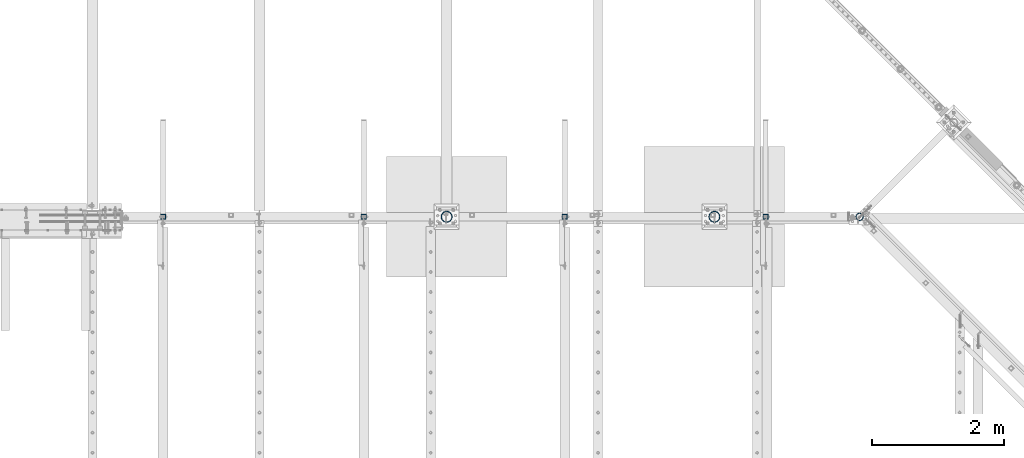
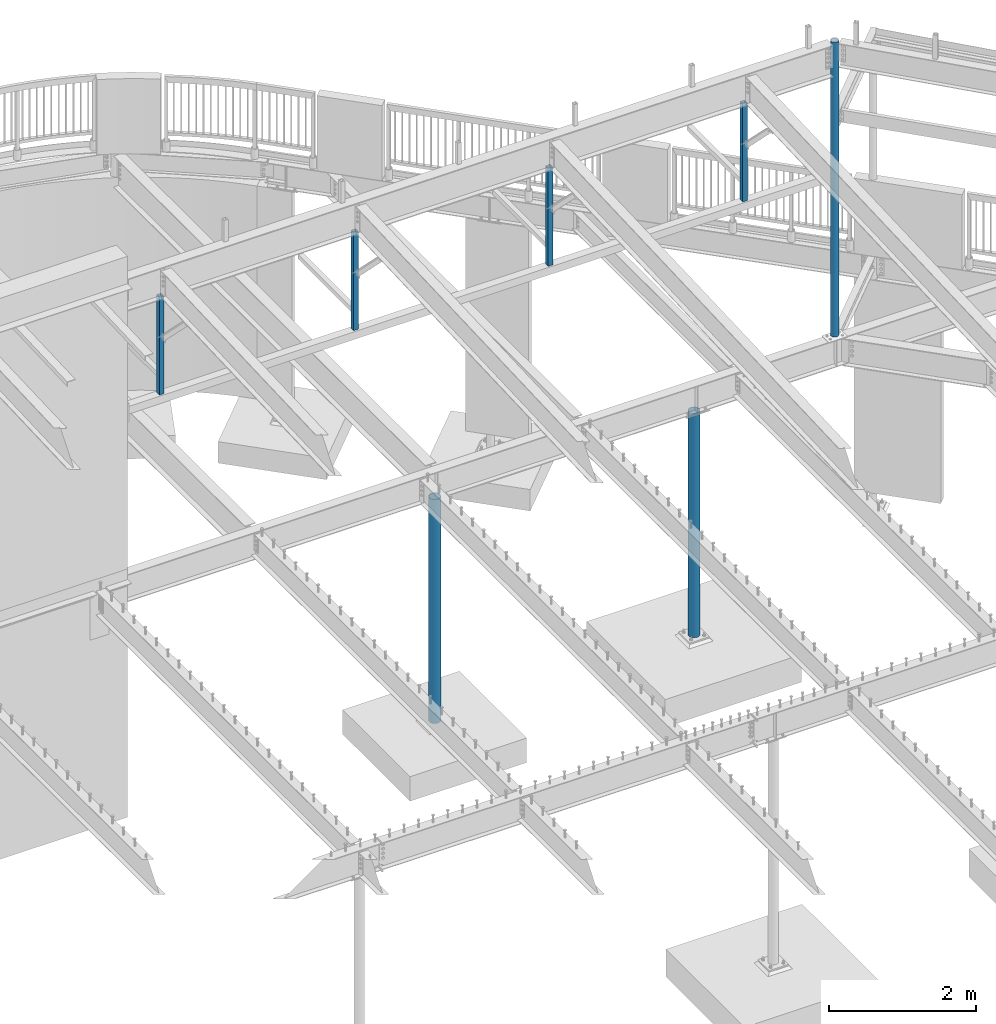
# One storey, part 128 of 975: 7 columns.
"""IFC2X3 building model written with IfcOpenShell, lengths in millimetres."""

from ifc_helpers import new_model, si_unit, frame, origin_with_axes, place, context, subcontext, project, spatial, faceted_brep, material, type_object, element, save


model = new_model("IFC2X3")

# Units and contexts
model_context = context("Model", 3, precision=1e-05, world=origin_with_axes())
body_context = subcontext(model_context, "Body", "Model", "MODEL_VIEW")
ifc_project = project(units=[si_unit("LENGTHUNIT", "METRE", prefix="MILLI"), si_unit("AREAUNIT", "SQUARE_METRE"), si_unit("VOLUMEUNIT", "CUBIC_METRE"), si_unit("MASSUNIT", "GRAM", prefix="KILO"), si_unit("TIMEUNIT", "SECOND"), si_unit("PLANEANGLEUNIT", "RADIAN"), si_unit("SOLIDANGLEUNIT", "STERADIAN"), si_unit("THERMODYNAMICTEMPERATUREUNIT", "DEGREE_CELSIUS"), si_unit("LUMINOUSINTENSITYUNIT", "LUMEN")], contexts=[model_context])

# Site, building, storey
site_placement = place(None, origin_with_axes())
site = spatial("IfcSite", under=ifc_project, at=site_placement, CompositionType="ELEMENT")
building_placement = place(site_placement, origin_with_axes())
building = spatial("IfcBuilding", under=site, at=building_placement, Name="Undefined", CompositionType="ELEMENT")
storey_placement = place(building_placement, origin_with_axes())
storey = spatial("IfcBuildingStorey", under=building, at=storey_placement, Name="Undefined", CompositionType="ELEMENT", Elevation=0.0)

# Columns
ifc_material_1 = material()
column_type_1 = type_object("IfcColumnType", Name="HSS3X3X1/4", PredefinedType="NOTDEFINED")
for number, where, z_axis, x_axis in (
    (1, (23701.375, 20647.025, 6686.55), (1.0, 0.0, 0.0), (0.0, 0.0, 1.0)),
    (2, (20653.375, 20647.025, 6686.55), (1.0, 0.0, 0.0), (0.0, 0.0, 1.0)),
    (3, (17605.375, 20647.025, 6686.55), (1.0, 0.0, 0.0), (0.0, 0.0, 1.0)),
    (4, (14557.375, 20646.9149014879, 6686.55), (1.0, 0.0, 0.0), (0.0, 0.0, 1.0)),
):
    element("IfcColumn", number, at=place(storey_placement, frame(where, z_axis=z_axis, x_axis=x_axis)), inside=storey, type_object=column_type_1, material=ifc_material_1, ObjectType="HSS3X3X1/4", context=body_context, shape_type="Brep", body=[
        faceted_brep([(-5.45696821063757e-11, 31.7499999999909, -31.75000000002), (0.0, -31.7500000000146, -31.7500000000582), (1622.42500000001, -31.7499999992797, -31.75), (1622.42499999999, 31.7500000007203, -31.75), (0.0, -31.7500000000564, 31.7500000000073), (1622.42500000001, -31.7499999992797, 31.75), (0.0, 31.7500000000127, 31.7500000000582), (1622.42499999999, 31.7500000007203, 31.75), (-6.18456397205591e-11, 38.0999999999876, -38.1000000000258), (1.45519152283669e-10, 38.1000000000295, 38.1000000000386), (1622.42499999998, 38.1000000007189, 38.0999999999985), (1622.42499999998, 38.1000000007189, -38.0999999999985), (1.72803993336856e-11, -38.0999999999985, 38.0999999999985), (1622.42500000002, -38.0999999992819, 38.0999999999985), (-1.41881173476577e-10, -38.1000000000258, -38.1000000000386), (1622.42500000002, -38.0999999992819, -38.0999999999985)], [[[0, 1, 2, 3]], [[1, 4, 5, 2]], [[4, 6, 7, 5]], [[6, 0, 3, 7]], [[8, 9, 10, 11]], [[9, 12, 13, 10]], [[12, 14, 15, 13]], [[14, 8, 11, 15]], [[13, 15, 11, 10], [5, 7, 3, 2]], [[14, 12, 9, 8], [6, 4, 1, 0]]]),
    ])
ifc_material_2 = material(Name="STEEL/A53")
column_type_2 = type_object("IfcColumnType", Name="PIPE4STD", PredefinedType="NOTDEFINED")
column_1_placement = place(storey_placement, frame((25126.9920609686, 20647.025, 3937.0), z_axis=(0.0, 1.0, 0.0), x_axis=(0.0, 0.0, 1.0)))
element("IfcColumn", 5, at=column_1_placement, inside=storey, type_object=column_type_2, material=ifc_material_2, Name="COLUMN", ObjectType="PIPE4STD", context=body_context, shape_type="Brep", body=[
    faceted_brep([(12.7000000000007, -51.1301999999359, 6.54836185276508e-11), (12.7000000000007, -48.6277098894352, 15.8001007258354), (4892.675, -48.6277098894752, 15.8001007257917), (4892.675, -51.1301999999996, 0.0), (12.7000000000007, -41.3652007257788, 30.0535775067838), (4892.675, -41.3652007257915, 30.0535775067656), (12.7000000000007, -30.0535775067819, 41.3652007257842), (4892.675, -30.0535775067656, 41.3652007257915), (12.7000000000007, -15.8001007258317, 48.6277098894388), (4892.675, -15.8001007257917, 48.6277098894752), (12.7000000000007, -6.00266503170133e-11, 51.1301999999414), (4892.675, 0.0, 51.1301999999996), (12.7000000000007, 15.8001007257153, 48.6277098894025), (4892.675, 15.8001007257917, 48.6277098894752), (12.7000000000007, 30.0535775066819, 41.3652007257042), (4892.675, 30.0535775067656, 41.3652007257915), (12.7000000000007, 41.3652007257078, 30.0535775066783), (4892.675, 41.3652007257915, 30.0535775067656), (12.7000000000007, 48.6277098894061, 15.8001007257117), (4892.675, 48.6277098894752, 15.8001007257917), (12.7000000000007, 51.1301999999469, -6.54836185276508e-11), (4892.675, 51.1301999999996, 0.0), (12.7000000000007, 48.6277098894425, -15.8001007258354), (4892.675, 48.6277098894752, -15.8001007257917), (12.7000000000007, 41.3652007257861, -30.0535775067838), (4892.675, 41.3652007257915, -30.0535775067656), (12.7000000000007, 30.0535775067892, -41.3652007257842), (4892.675, 30.0535775067656, -41.3652007257915), (12.7000000000007, 15.800100725839, -48.6277098894388), (4892.675, 15.8001007257917, -48.6277098894752), (12.7000000000007, 7.09405867382884e-11, -51.1301999999414), (4892.675, 0.0, -51.1301999999996), (12.7000000000007, -15.8001007257044, -48.6277098893988), (4892.675, -15.8001007257917, -48.6277098894752), (12.7000000000007, -30.0535775066746, -41.3652007257042), (4892.675, -30.0535775067656, -41.3652007257915), (12.7000000000007, -41.3652007257006, -30.0535775066746), (4892.675, -41.3652007257915, -30.0535775067656), (12.7000000000007, -48.6277098893952, -15.800100725708), (4892.675, -48.6277098894752, -15.8001007257917), (12.7000000000007, -57.149999999936, 7.27595761418343e-11), (12.7000000000007, -54.3528799061787, -17.6603212284354), (4892.675, -54.3528799062697, -17.6603212285299), (4892.675, -57.1500000000015, 0.0), (12.7000000000007, -46.2353212284306, -33.5919271684179), (4892.675, -46.235321228527, -33.5919271685161), (12.7000000000007, -33.5919271684143, -46.2353212284324), (4892.675, -33.5919271685161, -46.235321228527), (12.7000000000007, -17.6603212284317, -54.3528799061824), (4892.675, -17.6603212285299, -54.3528799062697), (12.7000000000007, 7.45785655453801e-11, -57.149999999936), (4892.675, 0.0, -57.1500000000015), (12.7000000000007, 17.6603212285845, -54.3528799062296), (4892.675, 17.6603212285299, -54.3528799062697), (12.7000000000007, 33.5919271685379, -46.2353212285198), (4892.675, 33.5919271685161, -46.235321228527), (12.7000000000007, 46.2353212285234, -33.5919271685343), (4892.675, 46.235321228527, -33.5919271685161), (12.7000000000007, 54.3528799062333, -17.6603212285772), (4892.675, 54.3528799062697, -17.6603212285299), (12.7000000000007, 57.1499999999414, -7.27595761418343e-11), (4892.675, 57.1500000000015, 0.0), (12.7000000000007, 54.3528799061896, 17.6603212284354), (4892.675, 54.3528799062697, 17.6603212285299), (12.7000000000007, 46.2353212284361, 33.5919271684179), (4892.675, 46.235321228527, 33.5919271685161), (12.7000000000007, 33.5919271684197, 46.2353212284361), (4892.675, 33.5919271685161, 46.235321228527), (12.7000000000007, 17.6603212284426, 54.3528799061824), (4892.675, 17.6603212285299, 54.3528799062697), (12.7000000000007, -6.91215973347425e-11, 57.1499999999396), (4892.675, 0.0, 57.1500000000015), (12.7000000000007, -17.6603212285736, 54.3528799062333), (4892.675, -17.6603212285299, 54.3528799062697), (12.7000000000007, -33.5919271685307, 46.2353212285234), (4892.675, -33.5919271685161, 46.235321228527), (12.7000000000007, -46.2353212285161, 33.5919271685343), (4892.675, -46.235321228527, 33.5919271685161), (12.7000000000007, -54.3528799062224, 17.6603212285772), (4892.675, -54.3528799062697, 17.6603212285299)], [[[0, 1, 2, 3]], [[1, 4, 5, 2]], [[4, 6, 7, 5]], [[6, 8, 9, 7]], [[8, 10, 11, 9]], [[10, 12, 13, 11]], [[12, 14, 15, 13]], [[14, 16, 17, 15]], [[16, 18, 19, 17]], [[18, 20, 21, 19]], [[20, 22, 23, 21]], [[22, 24, 25, 23]], [[24, 26, 27, 25]], [[26, 28, 29, 27]], [[28, 30, 31, 29]], [[30, 32, 33, 31]], [[32, 34, 35, 33]], [[34, 36, 37, 35]], [[36, 38, 39, 37]], [[38, 0, 3, 39]], [[40, 41, 42, 43]], [[41, 44, 45, 42]], [[44, 46, 47, 45]], [[46, 48, 49, 47]], [[48, 50, 51, 49]], [[50, 52, 53, 51]], [[52, 54, 55, 53]], [[54, 56, 57, 55]], [[56, 58, 59, 57]], [[58, 60, 61, 59]], [[60, 62, 63, 61]], [[62, 64, 65, 63]], [[64, 66, 67, 65]], [[66, 68, 69, 67]], [[68, 70, 71, 69]], [[70, 72, 73, 71]], [[72, 74, 75, 73]], [[74, 76, 77, 75]], [[76, 78, 79, 77]], [[78, 40, 43, 79]], [[45, 47, 49, 51, 53, 55, 57, 59, 61, 63, 65, 67, 69, 71, 73, 75, 77, 79, 43, 42], [5, 7, 9, 11, 13, 15, 17, 19, 21, 23, 25, 27, 29, 31, 33, 35, 37, 39, 3, 2]], [[78, 76, 74, 72, 70, 68, 66, 64, 62, 60, 58, 56, 54, 52, 50, 48, 46, 44, 41, 40], [38, 36, 34, 32, 30, 28, 26, 24, 22, 20, 18, 16, 14, 12, 10, 8, 6, 4, 1, 0]]]),
])
column_type_3 = type_object("IfcColumnType", Name="PIPE6STD", PredefinedType="NOTDEFINED")
column_2_placement = place(storey_placement, frame((22923.5, 20647.025, -266.7), z_axis=(0.0, 1.0, 0.0), x_axis=(0.0, 0.0, 1.0)))
element("IfcColumn", 6, at=column_2_placement, inside=storey, type_object=column_type_3, material=ifc_material_2, Name="COLUMN", ObjectType="PIPE6STD", context=body_context, shape_type="Brep", body=[
    faceted_brep([(25.3999999999999, -77.0889999999999, 0.0), (25.3999999999999, -74.4622560227981, 19.9521013679077), (3736.975, -74.4622560227981, 19.9521013679077), (3736.975, -77.0889999999999, 0.0), (25.3999999999999, -66.7610323523368, 38.5445), (3736.975, -66.7610323523368, 38.5445), (25.3999999999999, -54.5101546548904, 54.5101546548904), (3736.975, -54.5101546548904, 54.5101546548904), (25.3999999999999, -38.5445, 66.7610323523404), (3736.975, -38.5445, 66.7610323523404), (25.3999999999999, -19.9521013679077, 74.4622560227981), (3736.975, -19.9521013679077, 74.4622560227981), (25.3999999999999, 0.0, 77.0889999999999), (3736.975, 0.0, 77.0889999999999), (25.3999999999999, 19.9521013679077, 74.4622560227981), (3736.975, 19.9521013679077, 74.4622560227981), (25.3999999999999, 38.5445, 66.7610323523368), (3736.975, 38.5445, 66.7610323523368), (25.3999999999999, 54.5101546548904, 54.5101546548904), (3736.975, 54.5101546548904, 54.5101546548904), (25.3999999999999, 66.7610323523404, 38.5445), (3736.975, 66.7610323523404, 38.5445), (25.3999999999999, 74.4622560227981, 19.9521013679077), (3736.975, 74.4622560227981, 19.9521013679077), (25.3999999999999, 77.0889999999999, 0.0), (3736.975, 77.0889999999999, 0.0), (25.3999999999999, 74.4622560227981, -19.9521013679077), (3736.975, 74.4622560227981, -19.9521013679077), (25.3999999999999, 66.7610323523368, -38.5445), (3736.975, 66.7610323523368, -38.5445), (25.3999999999999, 54.5101546548904, -54.5101546548904), (3736.975, 54.5101546548904, -54.5101546548904), (25.3999999999999, 38.5445, -66.7610323523404), (3736.975, 38.5445, -66.7610323523404), (25.3999999999999, 19.9521013679077, -74.4622560227981), (3736.975, 19.9521013679077, -74.4622560227981), (25.3999999999999, 0.0, -77.0889999999999), (3736.975, 0.0, -77.0889999999999), (25.3999999999999, -19.9521013679077, -74.4622560227981), (3736.975, -19.9521013679077, -74.4622560227981), (25.3999999999999, -38.5445, -66.7610323523404), (3736.975, -38.5445, -66.7610323523404), (25.3999999999999, -54.5101546548904, -54.5101546548904), (3736.975, -54.5101546548904, -54.5101546548904), (25.3999999999999, -66.7610323523404, -38.5445), (3736.975, -66.7610323523404, -38.5445), (25.3999999999999, -74.4622560227981, -19.9521013679077), (3736.975, -74.4622560227981, -19.9521013679077), (25.3999999999999, -84.2010000000009, 0.0), (25.3999999999999, -81.3319204993641, -21.792822416679), (3736.975, -81.3319204993641, -21.792822416679), (3736.975, -84.2010000000009, 0.0), (25.3999999999999, -72.9202050240528, -42.1005000000005), (3736.975, -72.9202050240528, -42.1005000000005), (25.3999999999999, -59.5390980826887, -59.5390980826887), (3736.975, -59.5390980826887, -59.5390980826887), (25.3999999999999, -42.1005000000005, -72.9202050240528), (3736.975, -42.1005000000005, -72.9202050240528), (25.3999999999999, -21.792822416679, -81.3319204993641), (3736.975, -21.792822416679, -81.3319204993641), (25.3999999999999, 0.0, -84.2010000000009), (3736.975, 0.0, -84.2010000000009), (25.3999999999999, 21.792822416679, -81.3319204993641), (3736.975, 21.792822416679, -81.3319204993641), (25.3999999999999, 42.1005000000005, -72.9202050240528), (3736.975, 42.1005000000005, -72.9202050240528), (25.3999999999999, 59.5390980826887, -59.5390980826887), (3736.975, 59.5390980826887, -59.5390980826887), (25.3999999999999, 72.9202050240528, -42.1005000000005), (3736.975, 72.9202050240528, -42.1005000000005), (25.3999999999999, 81.3319204993641, -21.792822416679), (3736.975, 81.3319204993641, -21.792822416679), (25.3999999999999, 84.2010000000009, 0.0), (3736.975, 84.2010000000009, 0.0), (25.3999999999999, 81.3319204993641, 21.792822416679), (3736.975, 81.3319204993641, 21.792822416679), (25.3999999999999, 72.9202050240528, 42.1005000000005), (3736.975, 72.9202050240528, 42.1005000000005), (25.3999999999999, 59.5390980826887, 59.5390980826887), (3736.975, 59.5390980826887, 59.5390980826887), (25.3999999999999, 42.1005000000005, 72.9202050240528), (3736.975, 42.1005000000005, 72.9202050240528), (25.3999999999999, 21.792822416679, 81.3319204993641), (3736.975, 21.792822416679, 81.3319204993641), (25.3999999999999, 0.0, 84.2010000000009), (3736.975, 0.0, 84.2010000000009), (25.3999999999999, -21.792822416679, 81.3319204993641), (3736.975, -21.792822416679, 81.3319204993641), (25.3999999999999, -42.1005000000005, 72.9202050240528), (3736.975, -42.1005000000005, 72.9202050240528), (25.3999999999999, -59.5390980826887, 59.5390980826887), (3736.975, -59.5390980826887, 59.5390980826887), (25.3999999999999, -72.9202050240528, 42.1005000000005), (3736.975, -72.9202050240528, 42.1005000000005), (25.3999999999999, -81.3319204993641, 21.792822416679), (3736.975, -81.3319204993641, 21.792822416679)], [[[0, 1, 2, 3]], [[1, 4, 5, 2]], [[4, 6, 7, 5]], [[6, 8, 9, 7]], [[8, 10, 11, 9]], [[10, 12, 13, 11]], [[12, 14, 15, 13]], [[14, 16, 17, 15]], [[16, 18, 19, 17]], [[18, 20, 21, 19]], [[20, 22, 23, 21]], [[22, 24, 25, 23]], [[24, 26, 27, 25]], [[26, 28, 29, 27]], [[28, 30, 31, 29]], [[30, 32, 33, 31]], [[32, 34, 35, 33]], [[34, 36, 37, 35]], [[36, 38, 39, 37]], [[38, 40, 41, 39]], [[40, 42, 43, 41]], [[42, 44, 45, 43]], [[44, 46, 47, 45]], [[46, 0, 3, 47]], [[48, 49, 50, 51]], [[49, 52, 53, 50]], [[52, 54, 55, 53]], [[54, 56, 57, 55]], [[56, 58, 59, 57]], [[58, 60, 61, 59]], [[60, 62, 63, 61]], [[62, 64, 65, 63]], [[64, 66, 67, 65]], [[66, 68, 69, 67]], [[68, 70, 71, 69]], [[70, 72, 73, 71]], [[72, 74, 75, 73]], [[74, 76, 77, 75]], [[76, 78, 79, 77]], [[78, 80, 81, 79]], [[80, 82, 83, 81]], [[82, 84, 85, 83]], [[84, 86, 87, 85]], [[86, 88, 89, 87]], [[88, 90, 91, 89]], [[90, 92, 93, 91]], [[92, 94, 95, 93]], [[94, 48, 51, 95]], [[53, 55, 57, 59, 61, 63, 65, 67, 69, 71, 73, 75, 77, 79, 81, 83, 85, 87, 89, 91, 93, 95, 51, 50], [5, 7, 9, 11, 13, 15, 17, 19, 21, 23, 25, 27, 29, 31, 33, 35, 37, 39, 41, 43, 45, 47, 3, 2]], [[94, 92, 90, 88, 86, 84, 82, 80, 78, 76, 74, 72, 70, 68, 66, 64, 62, 60, 58, 56, 54, 52, 49, 48], [46, 44, 42, 40, 38, 36, 34, 32, 30, 28, 26, 24, 22, 20, 18, 16, 14, 12, 10, 8, 6, 4, 1, 0]]]),
])
column_3_placement = place(storey_placement, frame((18859.5, 20647.025, -266.7), z_axis=(0.0, 1.0, 0.0), x_axis=(0.0, 0.0, 1.0)))
element("IfcColumn", 7, at=column_3_placement, inside=storey, type_object=column_type_3, material=ifc_material_2, Name="COLUMN", ObjectType="PIPE6STD", context=body_context, shape_type="Brep", body=[
    faceted_brep([(25.3999999999999, -77.0889999999999, 0.0), (25.3999999999999, -74.4622560227981, 19.9521013679077), (3736.975, -74.4622560227981, 19.9521013679077), (3736.975, -77.0889999999999, 0.0), (25.3999999999999, -66.7610323523368, 38.5445), (3736.975, -66.7610323523368, 38.5445), (25.3999999999999, -54.5101546548904, 54.5101546548904), (3736.975, -54.5101546548904, 54.5101546548904), (25.3999999999999, -38.5445, 66.7610323523404), (3736.975, -38.5445, 66.7610323523404), (25.3999999999999, -19.9521013679077, 74.4622560227981), (3736.975, -19.9521013679077, 74.4622560227981), (25.3999999999999, 0.0, 77.0889999999999), (3736.975, 0.0, 77.0889999999999), (25.3999999999999, 19.9521013679077, 74.4622560227981), (3736.975, 19.9521013679077, 74.4622560227981), (25.3999999999999, 38.5445, 66.7610323523368), (3736.975, 38.5445, 66.7610323523368), (25.3999999999999, 54.5101546548904, 54.5101546548904), (3736.975, 54.5101546548904, 54.5101546548904), (25.3999999999999, 66.7610323523404, 38.5445), (3736.975, 66.7610323523404, 38.5445), (25.3999999999999, 74.4622560227981, 19.9521013679077), (3736.975, 74.4622560227981, 19.9521013679077), (25.3999999999999, 77.0889999999999, 0.0), (3736.975, 77.0889999999999, 0.0), (25.3999999999999, 74.4622560227981, -19.9521013679077), (3736.975, 74.4622560227981, -19.9521013679077), (25.3999999999999, 66.7610323523368, -38.5445), (3736.975, 66.7610323523368, -38.5445), (25.3999999999999, 54.5101546548904, -54.5101546548904), (3736.975, 54.5101546548904, -54.5101546548904), (25.3999999999999, 38.5445, -66.7610323523404), (3736.975, 38.5445, -66.7610323523404), (25.3999999999999, 19.9521013679077, -74.4622560227981), (3736.975, 19.9521013679077, -74.4622560227981), (25.3999999999999, 0.0, -77.0889999999999), (3736.975, 0.0, -77.0889999999999), (25.3999999999999, -19.9521013679077, -74.4622560227981), (3736.975, -19.9521013679077, -74.4622560227981), (25.3999999999999, -38.5445, -66.7610323523404), (3736.975, -38.5445, -66.7610323523404), (25.3999999999999, -54.5101546548904, -54.5101546548904), (3736.975, -54.5101546548904, -54.5101546548904), (25.3999999999999, -66.7610323523404, -38.5445), (3736.975, -66.7610323523404, -38.5445), (25.3999999999999, -74.4622560227981, -19.9521013679077), (3736.975, -74.4622560227981, -19.9521013679077), (25.3999999999999, -84.2010000000009, 0.0), (25.3999999999999, -81.3319204993641, -21.792822416679), (3736.975, -81.3319204993641, -21.792822416679), (3736.975, -84.2010000000009, 0.0), (25.3999999999999, -72.9202050240528, -42.1005000000005), (3736.975, -72.9202050240528, -42.1005000000005), (25.3999999999999, -59.5390980826887, -59.5390980826887), (3736.975, -59.5390980826887, -59.5390980826887), (25.3999999999999, -42.1005000000005, -72.9202050240528), (3736.975, -42.1005000000005, -72.9202050240528), (25.3999999999999, -21.792822416679, -81.3319204993641), (3736.975, -21.792822416679, -81.3319204993641), (25.3999999999999, 0.0, -84.2010000000009), (3736.975, 0.0, -84.2010000000009), (25.3999999999999, 21.792822416679, -81.3319204993641), (3736.975, 21.792822416679, -81.3319204993641), (25.3999999999999, 42.1005000000005, -72.9202050240528), (3736.975, 42.1005000000005, -72.9202050240528), (25.3999999999999, 59.5390980826887, -59.5390980826887), (3736.975, 59.5390980826887, -59.5390980826887), (25.3999999999999, 72.9202050240528, -42.1005000000005), (3736.975, 72.9202050240528, -42.1005000000005), (25.3999999999999, 81.3319204993641, -21.792822416679), (3736.975, 81.3319204993641, -21.792822416679), (25.3999999999999, 84.2010000000009, 0.0), (3736.975, 84.2010000000009, 0.0), (25.3999999999999, 81.3319204993641, 21.792822416679), (3736.975, 81.3319204993641, 21.792822416679), (25.3999999999999, 72.9202050240528, 42.1005000000005), (3736.975, 72.9202050240528, 42.1005000000005), (25.3999999999999, 59.5390980826887, 59.5390980826887), (3736.975, 59.5390980826887, 59.5390980826887), (25.3999999999999, 42.1005000000005, 72.9202050240528), (3736.975, 42.1005000000005, 72.9202050240528), (25.3999999999999, 21.792822416679, 81.3319204993641), (3736.975, 21.792822416679, 81.3319204993641), (25.3999999999999, 0.0, 84.2010000000009), (3736.975, 0.0, 84.2010000000009), (25.3999999999999, -21.792822416679, 81.3319204993641), (3736.975, -21.792822416679, 81.3319204993641), (25.3999999999999, -42.1005000000005, 72.9202050240528), (3736.975, -42.1005000000005, 72.9202050240528), (25.3999999999999, -59.5390980826887, 59.5390980826887), (3736.975, -59.5390980826887, 59.5390980826887), (25.3999999999999, -72.9202050240528, 42.1005000000005), (3736.975, -72.9202050240528, 42.1005000000005), (25.3999999999999, -81.3319204993641, 21.792822416679), (3736.975, -81.3319204993641, 21.792822416679)], [[[0, 1, 2, 3]], [[1, 4, 5, 2]], [[4, 6, 7, 5]], [[6, 8, 9, 7]], [[8, 10, 11, 9]], [[10, 12, 13, 11]], [[12, 14, 15, 13]], [[14, 16, 17, 15]], [[16, 18, 19, 17]], [[18, 20, 21, 19]], [[20, 22, 23, 21]], [[22, 24, 25, 23]], [[24, 26, 27, 25]], [[26, 28, 29, 27]], [[28, 30, 31, 29]], [[30, 32, 33, 31]], [[32, 34, 35, 33]], [[34, 36, 37, 35]], [[36, 38, 39, 37]], [[38, 40, 41, 39]], [[40, 42, 43, 41]], [[42, 44, 45, 43]], [[44, 46, 47, 45]], [[46, 0, 3, 47]], [[48, 49, 50, 51]], [[49, 52, 53, 50]], [[52, 54, 55, 53]], [[54, 56, 57, 55]], [[56, 58, 59, 57]], [[58, 60, 61, 59]], [[60, 62, 63, 61]], [[62, 64, 65, 63]], [[64, 66, 67, 65]], [[66, 68, 69, 67]], [[68, 70, 71, 69]], [[70, 72, 73, 71]], [[72, 74, 75, 73]], [[74, 76, 77, 75]], [[76, 78, 79, 77]], [[78, 80, 81, 79]], [[80, 82, 83, 81]], [[82, 84, 85, 83]], [[84, 86, 87, 85]], [[86, 88, 89, 87]], [[88, 90, 91, 89]], [[90, 92, 93, 91]], [[92, 94, 95, 93]], [[94, 48, 51, 95]], [[53, 55, 57, 59, 61, 63, 65, 67, 69, 71, 73, 75, 77, 79, 81, 83, 85, 87, 89, 91, 93, 95, 51, 50], [5, 7, 9, 11, 13, 15, 17, 19, 21, 23, 25, 27, 29, 31, 33, 35, 37, 39, 41, 43, 45, 47, 3, 2]], [[94, 92, 90, 88, 86, 84, 82, 80, 78, 76, 74, 72, 70, 68, 66, 64, 62, 60, 58, 56, 54, 52, 49, 48], [46, 44, 42, 40, 38, 36, 34, 32, 30, 28, 26, 24, 22, 20, 18, 16, 14, 12, 10, 8, 6, 4, 1, 0]]]),
])

save(model, "model.ifc")
